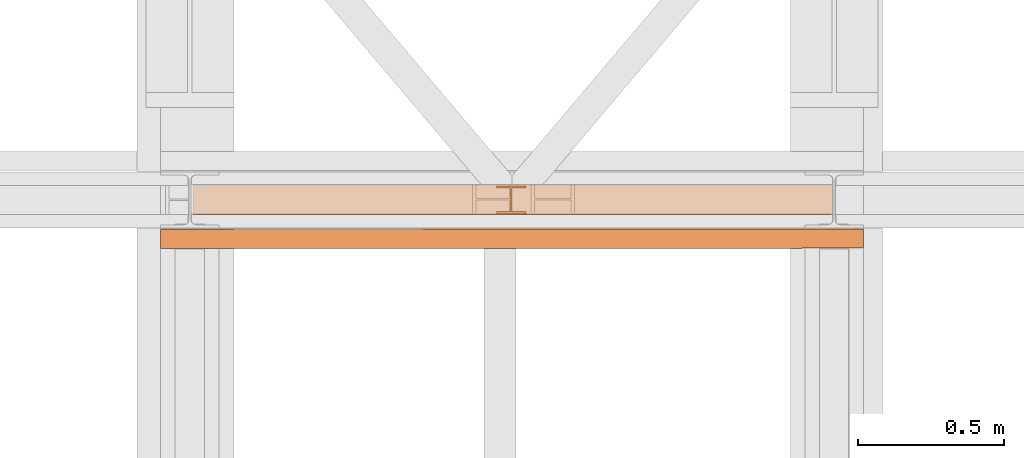
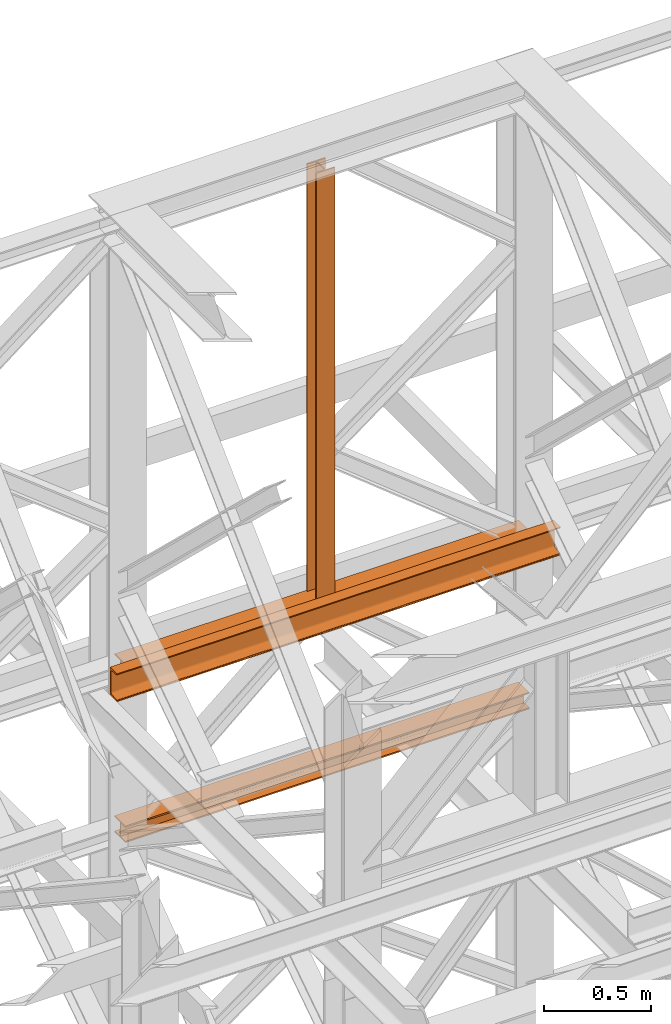
# One storey, part 120 of 208: 4 proxies.
"""IFC2X3 building model written with IfcOpenShell, lengths in millimetres."""

from ifc_helpers import new_model, entity, si_unit, converted_unit, frame, origin, origin_with_axes, place, context, subcontext, project, spatial, faceted_brep, element, save


model = new_model("IFC2X3")

# Units and contexts
model_context = context("Model", 3, precision=1e-05, world=origin())
plan_context = context("Plan", 3, precision=1e-05, world=origin())
body_context = subcontext(model_context, "Body", "Model", "MODEL_VIEW")
ifc_project = project(units=[si_unit("LENGTHUNIT", "METRE", prefix="MILLI"), converted_unit("PLANEANGLEUNIT", "DEGREE", entity("IfcPlaneAngleMeasure", 0.0174532925199433), si_unit("PLANEANGLEUNIT", "RADIAN"), dimensions=[0, 0, 0, 0, 0, 0, 0]), si_unit("AREAUNIT", "SQUARE_METRE"), si_unit("VOLUMEUNIT", "CUBIC_METRE")], contexts=[model_context, plan_context])

# Building, storey
building_placement = place(None, origin())
building = spatial("IfcBuilding", under=ifc_project, at=building_placement, CompositionType="COMPLEX")
storey_placement = place(building_placement, origin_with_axes())
storey = spatial("IfcBuildingStorey", under=building, at=storey_placement, Name="Geschoss", CompositionType="ELEMENT")

# Proxies
proxy_1_placement = place(storey_placement, frame((1040.305342082056, -13810.57439404318, 9798.105713222345), z_axis=(0.0, 0.0, 1.0), x_axis=(1.0, 0.0, 0.0)))
element("IfcBuildingElementProxy", 1, at=proxy_1_placement, inside=storey, context=body_context, shape_type="Brep", body=[
    faceted_brep([(100.0100000000036, 88.01000000000022, 0.01000000000021828), (100.0100000000036, 96.01000000000022, 0.01000000000021828), (0.01000000000362888, 96.01000000000022, 0.01000000000021828), (0.01000000000362888, 88.01000000000022, 0.01000000000021828), (47.51000000000363, 88.01000000000022, 0.01000000000021828), (47.51000000000363, 8.010000000000218, 0.01000000000021828), (0.01000000000362888, 8.010000000000218, 0.01000000000021828), (0.01000000000362888, 0.01000000000021828, 0.01000000000021828), (100.0100000000036, 0.01000000000021828, 0.01000000000021828), (100.0100000000036, 8.010000000000218, 0.01000000000021828), (52.51000000000363, 8.010000000000218, 0.01000000000021828), (52.51000000000363, 88.01000000000022, 0.01000000000021828), (100.0100000000036, 96.01000000000022, 0.01000000000021828), (100.0100000000036, 88.01000000000022, 0.01000000000021828), (100.01, 88.01000000000022, 2451.894345471463), (100.01, 96.01000000000022, 2451.894345471463), (0.01000000000362888, 96.01000000000022, 0.01000000000021828), (100.0100000000036, 96.01000000000022, 0.01000000000021828), (100.01, 96.01000000000022, 2451.894345471463), (0.009999999999990905, 96.01000000000022, 2451.894345471463), (0.01000000000362888, 88.01000000000022, 0.01000000000021828), (0.01000000000362888, 96.01000000000022, 0.01000000000021828), (0.009999999999990905, 96.01000000000022, 2451.894345471463), (0.009999999999990905, 88.01000000000022, 2451.894345471463), (47.51000000000363, 88.01000000000022, 0.01000000000021828), (0.01000000000362888, 88.01000000000022, 0.01000000000021828), (0.009999999999990905, 88.01000000000022, 2451.894345471463), (47.50999999999999, 88.01000000000022, 2451.894345471463), (47.51000000000363, 8.010000000000218, 0.01000000000021828), (47.51000000000363, 88.01000000000022, 0.01000000000021828), (47.50999999999999, 88.01000000000022, 2451.894345471463), (47.50999999999999, 8.010000000000218, 2451.894345471463), (0.01000000000362888, 8.010000000000218, 0.01000000000021828), (47.51000000000363, 8.010000000000218, 0.01000000000021828), (47.50999999999999, 8.010000000000218, 2451.894345471463), (0.009999999999990905, 8.010000000000218, 2451.894345471463), (0.01000000000362888, 0.01000000000021828, 0.01000000000021828), (0.01000000000362888, 8.010000000000218, 0.01000000000021828), (0.009999999999990905, 8.010000000000218, 2451.894345471463), (0.009999999999990905, 0.01000000000021828, 2451.894345471463), (100.0100000000036, 0.01000000000021828, 0.01000000000021828), (0.01000000000362888, 0.01000000000021828, 0.01000000000021828), (0.009999999999990905, 0.01000000000021828, 2451.894345471463), (100.01, 0.01000000000021828, 2451.894345471463), (100.0100000000036, 8.010000000000218, 0.01000000000021828), (100.0100000000036, 0.01000000000021828, 0.01000000000021828), (100.01, 0.01000000000021828, 2451.894345471463), (100.01, 8.010000000000218, 2451.894345471463), (52.51000000000363, 8.010000000000218, 0.01000000000021828), (100.0100000000036, 8.010000000000218, 0.01000000000021828), (100.01, 8.010000000000218, 2451.894345471463), (52.50999999999999, 8.010000000000218, 2451.894345471463), (52.51000000000363, 88.01000000000022, 0.01000000000021828), (52.51000000000363, 8.010000000000218, 0.01000000000021828), (52.50999999999999, 8.010000000000218, 2451.894345471463), (52.50999999999999, 88.01000000000022, 2451.894345471463), (100.0100000000036, 88.01000000000022, 0.01000000000021828), (52.51000000000363, 88.01000000000022, 0.01000000000021828), (52.50999999999999, 88.01000000000022, 2451.894345471463), (100.01, 88.01000000000022, 2451.894345471463), (100.01, 88.01000000000022, 2451.894345471463), (52.50999999999999, 88.01000000000022, 2451.894345471463), (52.50999999999999, 8.010000000000218, 2451.894345471463), (100.01, 8.010000000000218, 2451.894345471463), (100.01, 0.01000000000021828, 2451.894345471463), (0.009999999999990905, 0.01000000000021828, 2451.894345471463), (0.009999999999990905, 8.010000000000218, 2451.894345471463), (47.50999999999999, 8.010000000000218, 2451.894345471463), (47.50999999999999, 88.01000000000022, 2451.894345471463), (0.009999999999990905, 88.01000000000022, 2451.894345471463), (0.009999999999990905, 96.01000000000022, 2451.894345471463), (100.01, 96.01000000000022, 2451.894345471463)], [[[0, 1, 2, 3, 4, 5, 6, 7, 8, 9, 10, 11]], [[12, 13, 14, 15]], [[16, 17, 18, 19]], [[20, 21, 22, 23]], [[24, 25, 26, 27]], [[28, 29, 30, 31]], [[32, 33, 34, 35]], [[36, 37, 38, 39]], [[40, 41, 42, 43]], [[44, 45, 46, 47]], [[48, 49, 50, 51]], [[52, 53, 54, 55]], [[56, 57, 58, 59]], [[60, 61, 62, 63, 64, 65, 66, 67, 68, 69, 70, 71]]], orient=[[False], [False], [False], [False], [False], [False], [False], [False], [False], [False], [False], [False], [False], [False]]),
])
proxy_2_placement = place(storey_placement, frame((5.189158585883206, -13812.57439031789, 9710.105713222343), z_axis=(0.0, 0.0, 1.0), x_axis=(1.0, 0.0, 0.0)))
element("IfcBuildingElementProxy", 2, at=proxy_2_placement, inside=storey, context=body_context, shape_type="Brep", body=[
    faceted_brep([(2184.825809875727, 0.01000000000021828, 8.010000000000218), (2184.825809875727, 47.51000000000022, 8.010000000000218), (2184.825809875727, 47.51000000000022, 88.01000000000204), (2184.825809875727, 0.01000000000021828, 88.01000000000204), (2184.825809875727, 0.01000000000021828, 96.01000000000022), (2184.825809875727, 100.0100000000002, 96.01000000000022), (2184.825809875727, 100.0100000000002, 88.01000000000204), (2184.825809875727, 52.51000000000022, 88.01000000000204), (2184.825809875727, 52.51000000000022, 8.010000000000218), (2184.825809875727, 100.0100000000002, 8.010000000000218), (2184.825809875727, 100.0100000000002, 0.01000000000021828), (2184.825809875727, 0.01000000000021828, 0.01000000000021828), (2184.825809875727, 0.01000000000021828, 0.01000000000021828), (0.009999999999990905, 0.01000000000385626, 0.01000000000203727), (0.009999999999990905, 0.01000000000385626, 8.010000000000218), (2184.825809875727, 0.01000000000021828, 8.010000000000218), (2184.825809875727, 100.0100000000002, 0.01000000000021828), (0.009999999999990905, 100.0100000000039, 0.01000000000021828), (0.009999999999990905, 0.01000000000385626, 0.01000000000203727), (2184.825809875727, 0.01000000000021828, 0.01000000000021828), (2184.825809875727, 100.0100000000002, 8.010000000000218), (0.009999999999990905, 100.0100000000039, 8.010000000000218), (0.009999999999990905, 100.0100000000039, 0.01000000000021828), (2184.825809875727, 100.0100000000002, 0.01000000000021828), (2184.825809875727, 52.51000000000022, 8.010000000000218), (0.009999999999990905, 52.51000000000386, 8.010000000000218), (0.009999999999990905, 100.0100000000039, 8.010000000000218), (2184.825809875727, 100.0100000000002, 8.010000000000218), (2184.825809875727, 52.51000000000022, 88.01000000000204), (0.009999999999990905, 52.51000000000386, 88.01000000000204), (0.009999999999990905, 52.51000000000386, 8.010000000000218), (2184.825809875727, 52.51000000000022, 8.010000000000218), (2184.825809875727, 100.0100000000002, 88.01000000000204), (0.009999999999990905, 100.0100000000039, 88.01000000000204), (0.009999999999990905, 52.51000000000386, 88.01000000000204), (2184.825809875727, 52.51000000000022, 88.01000000000204), (2184.825809875727, 100.0100000000002, 96.01000000000022), (0.009999999999990905, 100.0100000000039, 96.01000000000022), (0.009999999999990905, 100.0100000000039, 88.01000000000204), (2184.825809875727, 100.0100000000002, 88.01000000000204), (2184.825809875727, 0.01000000000021828, 96.01000000000022), (0.009999999999990905, 0.01000000000385626, 96.01000000000022), (0.009999999999990905, 100.0100000000039, 96.01000000000022), (2184.825809875727, 100.0100000000002, 96.01000000000022), (2184.825809875727, 0.01000000000021828, 88.01000000000204), (0.009999999999990905, 0.01000000000385626, 88.01000000000022), (0.009999999999990905, 0.01000000000385626, 96.01000000000022), (2184.825809875727, 0.01000000000021828, 96.01000000000022), (2184.825809875727, 47.51000000000022, 88.01000000000204), (0.009999999999990905, 47.51000000000386, 88.01000000000204), (0.009999999999990905, 0.01000000000385626, 88.01000000000022), (2184.825809875727, 0.01000000000021828, 88.01000000000204), (2184.825809875727, 47.51000000000022, 8.010000000000218), (0.009999999999990905, 47.51000000000386, 8.010000000000218), (0.009999999999990905, 47.51000000000386, 88.01000000000204), (2184.825809875727, 47.51000000000022, 88.01000000000204), (2184.825809875727, 0.01000000000021828, 8.010000000000218), (0.009999999999990905, 0.01000000000385626, 8.010000000000218), (0.009999999999990905, 47.51000000000386, 8.010000000000218), (2184.825809875727, 47.51000000000022, 8.010000000000218), (0.009999999999990905, 0.01000000000385626, 8.010000000000218), (0.009999999999990905, 0.01000000000385626, 0.01000000000203727), (0.009999999999990905, 100.0100000000039, 0.01000000000021828), (0.009999999999990905, 100.0100000000039, 8.010000000000218), (0.009999999999990905, 52.51000000000386, 8.010000000000218), (0.009999999999990905, 52.51000000000386, 88.01000000000204), (0.009999999999990905, 100.0100000000039, 88.01000000000204), (0.009999999999990905, 100.0100000000039, 96.01000000000022), (0.009999999999990905, 0.01000000000385626, 96.01000000000022), (0.009999999999990905, 0.01000000000385626, 88.01000000000022), (0.009999999999990905, 47.51000000000386, 88.01000000000204), (0.009999999999990905, 47.51000000000386, 8.010000000000218)], [[[0, 1, 2, 3, 4, 5, 6, 7, 8, 9, 10, 11]], [[12, 13, 14, 15]], [[16, 17, 18, 19]], [[20, 21, 22, 23]], [[24, 25, 26, 27]], [[28, 29, 30, 31]], [[32, 33, 34, 35]], [[36, 37, 38, 39]], [[40, 41, 42, 43]], [[44, 45, 46, 47]], [[48, 49, 50, 51]], [[52, 53, 54, 55]], [[56, 57, 58, 59]], [[60, 61, 62, 63, 64, 65, 66, 67, 68, 69, 70, 71]]], orient=[[False], [False], [False], [False], [False], [False], [False], [False], [False], [False], [False], [False], [False], [False]]),
])
proxy_3_placement = place(storey_placement, frame((5.189158585881387, -13812.57439031789, 8785.007354628786), z_axis=(0.0, 0.0, 1.0), x_axis=(1.0, 0.0, 0.0)))
element("IfcBuildingElementProxy", 3, at=proxy_3_placement, inside=storey, context=body_context, shape_type="Brep", body=[
    faceted_brep([(2184.825809875727, 0.01000000000021828, 8.010000000000218), (2184.825809875727, 47.51000000000022, 8.010000000000218), (2184.825809875727, 47.51000000000022, 88.01000000000204), (2184.825809875727, 0.01000000000021828, 88.01000000000204), (2184.825809875727, 0.01000000000021828, 96.01000000000022), (2184.825809875727, 100.0100000000002, 96.01000000000022), (2184.825809875727, 100.0100000000002, 88.01000000000204), (2184.825809875727, 52.51000000000022, 88.01000000000204), (2184.825809875727, 52.51000000000022, 8.010000000000218), (2184.825809875727, 100.0100000000002, 8.010000000000218), (2184.825809875727, 100.0100000000002, 0.01000000000021828), (2184.825809875727, 0.01000000000021828, 0.01000000000021828), (2184.825809875727, 0.01000000000021828, 0.01000000000021828), (0.009999999999990905, 0.01000000000385626, 0.01000000000203727), (0.009999999999990905, 0.01000000000385626, 8.010000000000218), (2184.825809875727, 0.01000000000021828, 8.010000000000218), (2184.825809875727, 100.0100000000002, 0.01000000000021828), (0.009999999999990905, 100.0100000000039, 0.01000000000021828), (0.009999999999990905, 0.01000000000385626, 0.01000000000203727), (2184.825809875727, 0.01000000000021828, 0.01000000000021828), (2184.825809875727, 100.0100000000002, 8.010000000000218), (0.009999999999990905, 100.0100000000039, 8.010000000000218), (0.009999999999990905, 100.0100000000039, 0.01000000000021828), (2184.825809875727, 100.0100000000002, 0.01000000000021828), (2184.825809875727, 52.51000000000022, 8.010000000000218), (0.009999999999990905, 52.51000000000386, 8.010000000000218), (0.009999999999990905, 100.0100000000039, 8.010000000000218), (2184.825809875727, 100.0100000000002, 8.010000000000218), (2184.825809875727, 52.51000000000022, 88.01000000000204), (0.009999999999990905, 52.51000000000386, 88.01000000000204), (0.009999999999990905, 52.51000000000386, 8.010000000000218), (2184.825809875727, 52.51000000000022, 8.010000000000218), (2184.825809875727, 100.0100000000002, 88.01000000000204), (0.009999999999990905, 100.0100000000039, 88.01000000000204), (0.009999999999990905, 52.51000000000386, 88.01000000000204), (2184.825809875727, 52.51000000000022, 88.01000000000204), (2184.825809875727, 100.0100000000002, 96.01000000000022), (0.009999999999990905, 100.0100000000039, 96.01000000000022), (0.009999999999990905, 100.0100000000039, 88.01000000000204), (2184.825809875727, 100.0100000000002, 88.01000000000204), (2184.825809875727, 0.01000000000021828, 96.01000000000022), (0.009999999999990905, 0.01000000000385626, 96.01000000000022), (0.009999999999990905, 100.0100000000039, 96.01000000000022), (2184.825809875727, 100.0100000000002, 96.01000000000022), (2184.825809875727, 0.01000000000021828, 88.01000000000204), (0.009999999999990905, 0.01000000000385626, 88.01000000000022), (0.009999999999990905, 0.01000000000385626, 96.01000000000022), (2184.825809875727, 0.01000000000021828, 96.01000000000022), (2184.825809875727, 47.51000000000022, 88.01000000000204), (0.009999999999990905, 47.51000000000386, 88.01000000000204), (0.009999999999990905, 0.01000000000385626, 88.01000000000022), (2184.825809875727, 0.01000000000021828, 88.01000000000204), (2184.825809875727, 47.51000000000022, 8.010000000000218), (0.009999999999990905, 47.51000000000386, 8.010000000000218), (0.009999999999990905, 47.51000000000386, 88.01000000000204), (2184.825809875727, 47.51000000000022, 88.01000000000204), (2184.825809875727, 0.01000000000021828, 8.010000000000218), (0.009999999999990905, 0.01000000000385626, 8.010000000000218), (0.009999999999990905, 47.51000000000386, 8.010000000000218), (2184.825809875727, 47.51000000000022, 8.010000000000218), (0.009999999999990905, 0.01000000000385626, 8.010000000000218), (0.009999999999990905, 0.01000000000385626, 0.01000000000203727), (0.009999999999990905, 100.0100000000039, 0.01000000000021828), (0.009999999999990905, 100.0100000000039, 8.010000000000218), (0.009999999999990905, 52.51000000000386, 8.010000000000218), (0.009999999999990905, 52.51000000000386, 88.01000000000204), (0.009999999999990905, 100.0100000000039, 88.01000000000204), (0.009999999999990905, 100.0100000000039, 96.01000000000022), (0.009999999999990905, 0.01000000000385626, 96.01000000000022), (0.009999999999990905, 0.01000000000385626, 88.01000000000022), (0.009999999999990905, 47.51000000000386, 88.01000000000204), (0.009999999999990905, 47.51000000000386, 8.010000000000218)], [[[0, 1, 2, 3, 4, 5, 6, 7, 8, 9, 10, 11]], [[12, 13, 14, 15]], [[16, 17, 18, 19]], [[20, 21, 22, 23]], [[24, 25, 26, 27]], [[28, 29, 30, 31]], [[32, 33, 34, 35]], [[36, 37, 38, 39]], [[40, 41, 42, 43]], [[44, 45, 46, 47]], [[48, 49, 50, 51]], [[52, 53, 54, 55]], [[56, 57, 58, 59]], [[60, 61, 62, 63, 64, 65, 66, 67, 68, 69, 70, 71]]], orient=[[False], [False], [False], [False], [False], [False], [False], [False], [False], [False], [False], [False], [False], [False]]),
])
proxy_4_placement = place(storey_placement, frame((-106.6304189177533, -13927.76858191269, 9699.99), z_axis=(0.0, 0.0, 1.0), x_axis=(1.0, 0.0, 0.0)))
element("IfcBuildingElementProxy", 4, at=proxy_4_placement, inside=storey, context=body_context, shape_type="Brep", body=[
    faceted_brep([(0.009999999999990905, 0.00999999999839929, 0.01000000000021828), (0.009999999999990905, 0.00999999999839929, 3.132428070246533), (2399.682354694371, 0.2527365771729819, 3.132428070246533), (2399.682354694371, 0.2527365771729819, 0.01000000000021828), (0.009999999999990905, 0.00999999999839929, 3.132428070246533), (0.009999999999990905, 0.2527365771729819, 4.748288908171162), (2399.682354694371, 0.4954731543457456, 4.748288908171162), (2399.682354694371, 0.2527365771729819, 3.132428070246533), (0.009999999999990905, 0.2527365771729819, 4.748288908171162), (0.009999999999990905, 0.9594677141431021, 6.221534443444398), (2399.682354694371, 1.202204291315866, 6.221534443444398), (2399.682354694371, 0.4954731543457456, 4.748288908171162), (0.009999999999990905, 0.9594677141431021, 6.221534443444398), (0.009999999999990905, 2.067848361530196, 7.422126703873801), (2399.682354694371, 2.310584938702959, 7.422126703873801), (2399.682354694371, 1.202204291315866, 6.221534443444398), (0.009999999999990905, 2.067848361530196, 7.422126703873801), (0.009999999999990905, 3.480043588513581, 8.244091391710754), (2399.682354694371, 3.722780165688164, 8.244091391710754), (2399.682354694371, 2.310584938702959, 7.422126703873801), (0.009999999999990905, 3.480043588513581, 8.244091391710754), (0.009999999999990905, 5.071401277442419, 8.614912102195376), (2399.682354694371, 5.314137854617002, 8.614912102195376), (2399.682354694371, 3.722780165688164, 8.244091391710754), (0.009999999999990905, 5.071401277442419, 8.614912102195376), (0.009999999999990905, 47.84732483396874, 12.0369859867169), (2399.682354694371, 48.09006141114332, 12.0369859867169), (2399.682354694371, 5.314137854617002, 8.614912102195376), (0.009999999999990905, 47.84732483396874, 12.0369859867169), (0.009999999999990905, 50.88537133101454, 12.74491643400506), (2399.682354694371, 51.12810790818912, 12.74491643400506), (2399.682354694371, 48.09006141114332, 12.0369859867169), (0.009999999999990905, 50.88537133101454, 12.74491643400506), (0.009999999999990905, 53.58138040071208, 14.31412174714933), (2399.682354694371, 53.82411697788666, 14.31412174714933), (2399.682354694371, 51.12810790818912, 12.74491643400506), (0.009999999999990905, 53.58138040071208, 14.31412174714933), (0.009999999999990905, 55.69737981845174, 16.60616151705835), (2399.682354694371, 55.94011639562632, 16.60616151705835), (2399.682354694371, 53.82411697788666, 14.31412174714933), (0.009999999999990905, 55.69737981845174, 16.60616151705835), (0.009999999999990905, 57.04659380721387, 19.41872117530875), (2399.682354694371, 57.28933038438663, 19.41872117530875), (2399.682354694371, 55.94011639562632, 16.60616151705835), (0.009999999999990905, 57.04659380721387, 19.41872117530875), (0.009999999999990905, 57.5099999999984, 22.50354641134618), (2399.682354694371, 57.75273657717298, 22.50354641134618), (2399.682354694371, 57.28933038438663, 19.41872117530875), (0.009999999999990905, 57.5099999999984, 22.50354641134618), (0.009999999999990905, 57.5099999999984, 137.5164535886524), (2399.682354694371, 57.75273657717298, 137.5164535886524), (2399.682354694371, 57.75273657717298, 22.50354641134618), (0.009999999999990905, 57.5099999999984, 137.5164535886524), (0.009999999999990905, 57.04659380721387, 140.6012788246917), (2399.682354694371, 57.28933038438663, 140.6012788246917), (2399.682354694371, 57.75273657717298, 137.5164535886524), (0.009999999999990905, 57.04659380721387, 140.6012788246917), (0.009999999999990905, 55.69737981845174, 143.4138384829403), (2399.682354694371, 55.94011639562632, 143.4138384829403), (2399.682354694371, 57.28933038438663, 140.6012788246917), (0.009999999999990905, 55.69737981845174, 143.4138384829403), (0.009999999999990905, 53.58138040071208, 145.7058782528493), (2399.682354694371, 53.82411697788666, 145.7058782528493), (2399.682354694371, 55.94011639562632, 143.4138384829403), (0.009999999999990905, 53.58138040071208, 145.7058782528493), (0.009999999999990905, 50.88537133101454, 147.2750835659936), (2399.682354694371, 51.12810790818912, 147.2750835659936), (2399.682354694371, 53.82411697788666, 145.7058782528493), (0.009999999999990905, 50.88537133101454, 147.2750835659936), (0.009999999999990905, 47.84732483396874, 147.9830140132817), (2399.682354694371, 48.09006141114332, 147.9830140132817), (2399.682354694371, 51.12810790818912, 147.2750835659936), (0.009999999999990905, 47.84732483396874, 147.9830140132817), (0.009999999999990905, 5.071401277442419, 151.4050878978032), (2399.682354694371, 5.314137854617002, 151.4050878978032), (2399.682354694371, 48.09006141114332, 147.9830140132817), (0.009999999999990905, 5.071401277442419, 151.4050878978032), (0.009999999999990905, 3.480043588513581, 151.7759086082879), (2399.682354694371, 3.722780165688164, 151.7759086082879), (2399.682354694371, 5.314137854617002, 151.4050878978032), (0.009999999999990905, 3.480043588513581, 151.7759086082879), (0.009999999999990905, 2.067848361530196, 152.5978732961248), (2399.682354694371, 2.310584938702959, 152.5978732961248), (2399.682354694371, 3.722780165688164, 151.7759086082879), (0.009999999999990905, 2.067848361530196, 152.5978732961248), (0.009999999999990905, 0.9594677141431021, 153.7984655565542), (2399.682354694371, 1.202204291315866, 153.7984655565542), (2399.682354694371, 2.310584938702959, 152.5978732961248), (0.009999999999990905, 0.9594677141431021, 153.7984655565542), (0.009999999999990905, 0.2527365771729819, 155.2717110918275), (2399.682354694371, 0.4954731543457456, 155.2717110918275), (2399.682354694371, 1.202204291315866, 153.7984655565542), (0.009999999999990905, 0.2527365771729819, 155.2717110918275), (0.009999999999990905, 0.00999999999839929, 156.8875719297521), (2399.682354694371, 0.2527365771729819, 156.8875719297521), (2399.682354694371, 0.4954731543457456, 155.2717110918275), (0.009999999999990905, 0.00999999999839929, 156.8875719297521), (0.009999999999990905, 0.00999999999839929, 160.0100000000002), (2399.682354694371, 0.2527365771729819, 160.0100000000002), (2399.682354694371, 0.2527365771729819, 156.8875719297521), (0.009999999999990905, 0.00999999999839929, 160.0100000000002), (0.009999999999990905, 65.0099999999984, 160.0100000000002), (2399.682354694371, 65.25273657717298, 160.0100000000002), (2399.682354694371, 0.2527365771729819, 160.0100000000002), (0.009999999999990905, 65.0099999999984, 160.0100000000002), (0.009999999999990905, 65.0099999999984, 0.01000000000021828), (2399.682354694371, 65.25273657717298, 0.01000000000021828), (2399.682354694371, 65.25273657717298, 160.0100000000002), (0.009999999999990905, 65.0099999999984, 0.01000000000021828), (0.009999999999990905, 0.00999999999839929, 0.01000000000021828), (2399.682354694371, 0.2527365771729819, 0.01000000000021828), (2399.682354694371, 65.25273657717298, 0.01000000000021828), (0.009999999999990905, 0.00999999999839929, 0.01000000000021828), (0.009999999999990905, 65.0099999999984, 0.01000000000021828), (0.009999999999990905, 65.0099999999984, 160.0100000000002), (0.009999999999990905, 0.00999999999839929, 160.0100000000002), (0.009999999999990905, 0.00999999999839929, 156.8875719297521), (0.009999999999990905, 0.2527365771729819, 155.2717110918275), (0.009999999999990905, 0.9594677141431021, 153.7984655565542), (0.009999999999990905, 2.067848361530196, 152.5978732961248), (0.009999999999990905, 3.480043588513581, 151.7759086082879), (0.009999999999990905, 5.071401277442419, 151.4050878978032), (0.009999999999990905, 47.84732483396874, 147.9830140132817), (0.009999999999990905, 50.88537133101454, 147.2750835659936), (0.009999999999990905, 53.58138040071208, 145.7058782528493), (0.009999999999990905, 55.69737981845174, 143.4138384829403), (0.009999999999990905, 57.04659380721387, 140.6012788246917), (0.009999999999990905, 57.5099999999984, 137.5164535886524), (0.009999999999990905, 57.5099999999984, 22.50354641134618), (0.009999999999990905, 57.04659380721387, 19.41872117530875), (0.009999999999990905, 55.69737981845174, 16.60616151705835), (0.009999999999990905, 53.58138040071208, 14.31412174714933), (0.009999999999990905, 50.88537133101454, 12.74491643400506), (0.009999999999990905, 47.84732483396874, 12.0369859867169), (0.009999999999990905, 5.071401277442419, 8.614912102195376), (0.009999999999990905, 3.480043588513581, 8.244091391710754), (0.009999999999990905, 2.067848361530196, 7.422126703873801), (0.009999999999990905, 0.9594677141431021, 6.221534443444398), (0.009999999999990905, 0.2527365771729819, 4.748288908171162), (0.009999999999990905, 0.00999999999839929, 3.132428070246533), (2399.682354694371, 0.2527365771729819, 0.01000000000021828), (2399.682354694371, 0.2527365771729819, 3.132428070246533), (2399.682354694371, 0.4954731543457456, 4.748288908171162), (2399.682354694371, 1.202204291315866, 6.221534443444398), (2399.682354694371, 2.310584938702959, 7.422126703873801), (2399.682354694371, 3.722780165688164, 8.244091391710754), (2399.682354694371, 5.314137854617002, 8.614912102195376), (2399.682354694371, 48.09006141114332, 12.0369859867169), (2399.682354694371, 51.12810790818912, 12.74491643400506), (2399.682354694371, 53.82411697788666, 14.31412174714933), (2399.682354694371, 55.94011639562632, 16.60616151705835), (2399.682354694371, 57.28933038438663, 19.41872117530875), (2399.682354694371, 57.75273657717298, 22.50354641134618), (2399.682354694371, 57.75273657717298, 137.5164535886524), (2399.682354694371, 57.28933038438663, 140.6012788246917), (2399.682354694371, 55.94011639562632, 143.4138384829403), (2399.682354694371, 53.82411697788666, 145.7058782528493), (2399.682354694371, 51.12810790818912, 147.2750835659936), (2399.682354694371, 48.09006141114332, 147.9830140132817), (2399.682354694371, 5.314137854617002, 151.4050878978032), (2399.682354694371, 3.722780165688164, 151.7759086082879), (2399.682354694371, 2.310584938702959, 152.5978732961248), (2399.682354694371, 1.202204291315866, 153.7984655565542), (2399.682354694371, 0.4954731543457456, 155.2717110918275), (2399.682354694371, 0.2527365771729819, 156.8875719297521), (2399.682354694371, 0.2527365771729819, 160.0100000000002), (2399.682354694371, 65.25273657717298, 160.0100000000002), (2399.682354694371, 65.25273657717298, 0.01000000000021828)], [[[0, 1, 2, 3]], [[4, 5, 6, 7]], [[8, 9, 10, 11]], [[12, 13, 14, 15]], [[16, 17, 18, 19]], [[20, 21, 22, 23]], [[24, 25, 26, 27]], [[28, 29, 30, 31]], [[32, 33, 34, 35]], [[36, 37, 38, 39]], [[40, 41, 42, 43]], [[44, 45, 46, 47]], [[48, 49, 50, 51]], [[52, 53, 54, 55]], [[56, 57, 58, 59]], [[60, 61, 62, 63]], [[64, 65, 66, 67]], [[68, 69, 70, 71]], [[72, 73, 74, 75]], [[76, 77, 78, 79]], [[80, 81, 82, 83]], [[84, 85, 86, 87]], [[88, 89, 90, 91]], [[92, 93, 94, 95]], [[96, 97, 98, 99]], [[100, 101, 102, 103]], [[104, 105, 106, 107]], [[108, 109, 110, 111]], [[112, 113, 114, 115, 116, 117, 118, 119, 120, 121, 122, 123, 124, 125, 126, 127, 128, 129, 130, 131, 132, 133, 134, 135, 136, 137, 138, 139]], [[140, 141, 142, 143, 144, 145, 146, 147, 148, 149, 150, 151, 152, 153, 154, 155, 156, 157, 158, 159, 160, 161, 162, 163, 164, 165, 166, 167]]], orient=[[False], [False], [False], [False], [False], [False], [False], [False], [False], [False], [False], [False], [False], [False], [False], [False], [False], [False], [False], [False], [False], [False], [False], [False], [False], [False], [False], [False], [False], [False]]),
])

save(model, "model.ifc")
